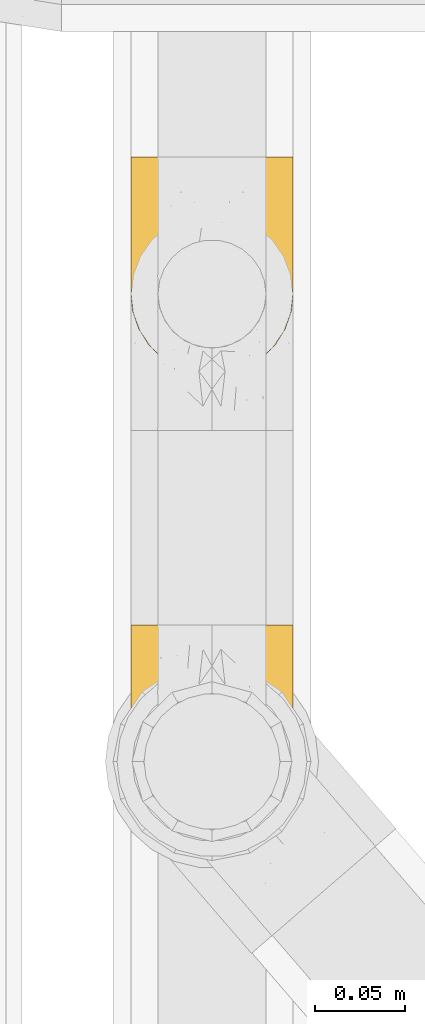
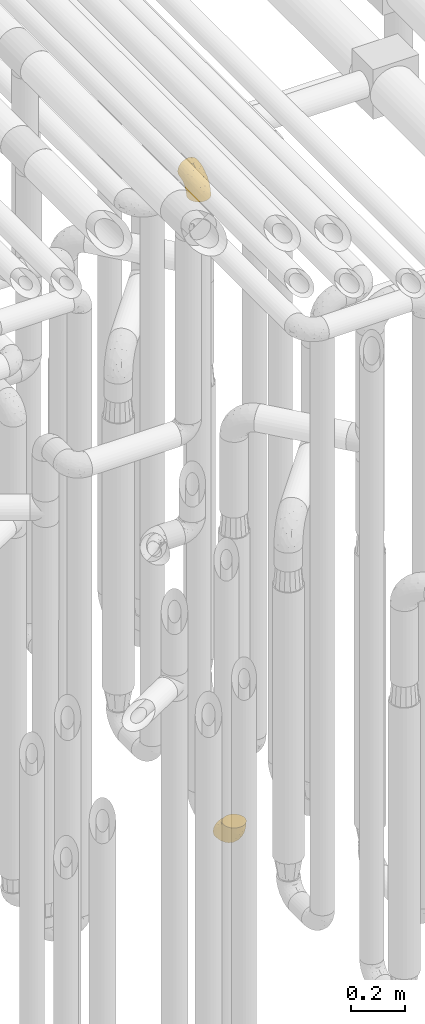
# One storey, part 213 of 827: 2 coverings.
"""IFC2X3 building model written with IfcOpenShell, lengths in millimetres."""

from ifc_helpers import new_model, entity, si_unit, converted_unit, derived_unit, direction, frame, origin, place, context, subcontext, project, spatial, faceted_brep, element, save


model = new_model("IFC2X3")

# Units and contexts
model_context = context("Model", 3, precision=0.01, world=origin(), true_north=direction((6.12303176911189e-17, 1.0)))
body_context = subcontext(model_context, "Body", "Model", "MODEL_VIEW")
ifc_project = project(units=[si_unit("LENGTHUNIT", "METRE", prefix="MILLI"), si_unit("AREAUNIT", "SQUARE_METRE"), si_unit("VOLUMEUNIT", "CUBIC_METRE"), converted_unit("PLANEANGLEUNIT", "DEGREE", entity("IfcRatioMeasure", 0.0174532925199433), si_unit("PLANEANGLEUNIT", "RADIAN"), dimensions=[0, 0, 0, 0, 0, 0, 0]), si_unit("MASSUNIT", "GRAM", prefix="KILO"), derived_unit("MASSDENSITYUNIT", [(si_unit("MASSUNIT", "GRAM", prefix="KILO"), 1), (si_unit("LENGTHUNIT", "METRE"), -3)]), derived_unit("MOMENTOFINERTIAUNIT", [(si_unit("LENGTHUNIT", "METRE"), 4)]), si_unit("TIMEUNIT", "SECOND"), si_unit("FREQUENCYUNIT", "HERTZ"), si_unit("THERMODYNAMICTEMPERATUREUNIT", "DEGREE_CELSIUS"), derived_unit("THERMALTRANSMITTANCEUNIT", [(si_unit("MASSUNIT", "GRAM", prefix="KILO"), 1), (si_unit("THERMODYNAMICTEMPERATUREUNIT", "KELVIN"), -1), (si_unit("TIMEUNIT", "SECOND"), -3)]), derived_unit("VOLUMETRICFLOWRATEUNIT", [(si_unit("LENGTHUNIT", "METRE"), 3), (si_unit("TIMEUNIT", "SECOND"), -1)]), derived_unit("MASSFLOWRATEUNIT", [(si_unit("MASSUNIT", "GRAM", prefix="KILO"), 1), (si_unit("TIMEUNIT", "SECOND"), -1)]), derived_unit("ROTATIONALFREQUENCYUNIT", [(si_unit("TIMEUNIT", "SECOND"), -1)]), si_unit("ELECTRICCURRENTUNIT", "AMPERE"), si_unit("ELECTRICVOLTAGEUNIT", "VOLT"), si_unit("POWERUNIT", "WATT"), si_unit("FORCEUNIT", "NEWTON", prefix="KILO"), si_unit("ILLUMINANCEUNIT", "LUX"), si_unit("LUMINOUSFLUXUNIT", "LUMEN"), si_unit("LUMINOUSINTENSITYUNIT", "CANDELA"), derived_unit("USERDEFINED", [(si_unit("MASSUNIT", "GRAM", prefix="KILO"), -1), (si_unit("LENGTHUNIT", "METRE"), -2), (si_unit("TIMEUNIT", "SECOND"), 3), (si_unit("LUMINOUSFLUXUNIT", "LUMEN"), 1)]), derived_unit("LINEARVELOCITYUNIT", [(si_unit("LENGTHUNIT", "METRE"), 1), (si_unit("TIMEUNIT", "SECOND"), -1)]), si_unit("PRESSUREUNIT", "PASCAL"), derived_unit("USERDEFINED", [(si_unit("LENGTHUNIT", "METRE"), -2), (si_unit("MASSUNIT", "GRAM", prefix="KILO"), 1), (si_unit("TIMEUNIT", "SECOND"), -2)]), derived_unit("LINEARFORCEUNIT", [(si_unit("MASSUNIT", "GRAM", prefix="KILO"), 1), (si_unit("LENGTHUNIT", "METRE"), 1), (si_unit("TIMEUNIT", "SECOND"), -2), (si_unit("LENGTHUNIT", "METRE"), -1)]), derived_unit("PLANARFORCEUNIT", [(si_unit("MASSUNIT", "GRAM", prefix="KILO"), 1), (si_unit("LENGTHUNIT", "METRE"), 1), (si_unit("TIMEUNIT", "SECOND"), -2), (si_unit("LENGTHUNIT", "METRE"), -2)])], contexts=[model_context])

# Site, building, storey
site_placement = place(None, origin())
site = spatial("IfcSite", under=ifc_project, at=site_placement, CompositionType="ELEMENT")
building_placement = place(site_placement, origin())
building = spatial("IfcBuilding", under=site, at=building_placement, CompositionType="ELEMENT")
storey_placement = place(building_placement, frame((0.0, 0.0, 28200.0)))
storey = spatial("IfcBuildingStorey", under=building, at=storey_placement, Name="08", CompositionType="ELEMENT", Elevation=28200.0)

# Coverings
covering_1_placement = place(storey_placement, frame((36582.9, 11683.46, 353.25)))
element("IfcCovering", 1, at=covering_1_placement, inside=storey, Name=":ADSK_", ObjectType=":ADSK_", PredefinedType="INSULATION", context=body_context, shape_type="Brep", body=[
    faceted_brep([(2.73, 36.69, 122.75), (6.07, 27.15, 122.75), (11.45, 18.59, 122.75), (18.6, 11.44, 122.75), (27.16, 6.06, 122.75), (36.7, 2.73, 122.75), (46.75, 1.6, 122.75), (56.8, 2.73, 122.75), (66.34, 6.07, 122.75), (74.9, 11.45, 122.75), (82.05, 18.6, 122.75), (87.43, 27.16, 122.75), (90.76, 36.7, 122.75), (91.9, 46.75, 122.75), (90.76, 56.8, 122.75), (87.42, 66.34, 122.75), (82.04, 74.9, 122.75), (74.89, 82.05, 122.75), (66.33, 87.43, 122.75), (56.79, 90.76, 122.75), (46.75, 91.9, 122.75), (36.69, 90.76, 122.75), (27.15, 87.42, 122.75), (18.59, 82.04, 122.75), (11.44, 74.89, 122.75), (6.06, 66.33, 122.75), (2.73, 56.79, 122.75), (1.6, 46.75, 122.75), (58.43, 122.75, 90.36), (69.32, 122.75, 85.85), (78.67, 122.75, 78.67), (85.85, 122.75, 69.32), (90.36, 122.75, 58.43), (91.9, 122.75, 46.75), (90.36, 122.75, 35.06), (85.85, 122.75, 24.17), (78.67, 122.75, 14.82), (69.32, 122.75, 7.64), (58.43, 122.75, 3.13), (46.75, 122.75, 1.6), (35.06, 122.75, 3.13), (24.17, 122.75, 7.64), (14.82, 122.75, 14.82), (7.64, 122.75, 24.17), (3.13, 122.75, 35.06), (1.6, 122.75, 46.75), (3.13, 122.75, 58.43), (7.64, 122.75, 69.32), (14.82, 122.75, 78.67), (24.17, 122.75, 85.85), (35.06, 122.75, 90.36), (46.75, 122.75, 91.9), (46.75, 24.73, 51.54), (38.29, 29.08, 47.17), (46.75, 38.13, 38.13), (46.75, 85.31, 7.52), (38.96, 93.59, 5.85), (46.75, 100.54, 5.11), (33.86, 63.54, 19.2), (31.42, 38.98, 38.98), (21.63, 50.71, 35.02), (30.84, 93.33, 8.21), (22.16, 75.2, 19.28), (20.56, 100.46, 12.19), (2.29, 41.6, 101.39), (7.18, 80.86, 34.43), (12.6, 94.87, 20.95), (14.0, 67.96, 30.74), (2.81, 52.16, 72.93), (6.65, 52.1, 56.64), (6.11, 36.74, 80.81), (16.62, 17.11, 93.43), (9.76, 23.24, 100.76), (12.46, 29.18, 74.27), (1.6, 52.53, 93.66), (1.6, 60.77, 81.33), (1.6, 69.01, 69.01), (2.46, 100.68, 40.87), (5.91, 103.79, 29.38), (36.97, 16.37, 67.05), (46.75, 7.52, 85.31), (33.09, 7.31, 93.68), (1.6, 93.66, 52.53), (1.6, 102.83, 50.71), (1.6, 112.01, 48.88), (25.62, 18.17, 72.77), (3.14, 71.97, 51.21), (23.92, 9.83, 101.18), (46.75, 5.11, 100.54), (13.58, 45.97, 48.74), (1.6, 48.88, 112.01), (1.6, 50.71, 102.83), (18.5, 22.83, 73.88), (46.75, 51.54, 24.73), (1.6, 81.33, 60.77), (4.96, 31.74, 103.08), (20.84, 32.48, 54.8), (46.75, 68.42, 16.13), (30.52, 25.33, 55.92), (46.75, 16.13, 68.42), (27.29, 92.29, 104.98), (36.89, 94.12, 108.58), (33.6, 100.97, 98.21), (2.54, 95.91, 61.56), (3.27, 107.9, 60.69), (16.85, 87.24, 100.0), (21.91, 95.46, 95.88), (13.5, 90.41, 90.81), (3.96, 74.17, 84.88), (3.52, 83.77, 73.29), (12.17, 76.72, 113.4), (18.93, 84.44, 109.8), (9.34, 76.42, 102.13), (3.12, 90.07, 67.29), (5.67, 99.69, 70.34), (2.51, 61.74, 95.15), (2.53, 58.16, 105.49), (8.35, 112.6, 71.5), (35.39, 110.45, 92.87), (46.75, 107.32, 96.03), (15.1, 108.48, 81.34), (5.27, 66.63, 107.44), (27.43, 115.23, 88.36), (24.89, 105.79, 90.43), (29.71, 89.6, 114.37), (5.07, 69.39, 98.41), (2.88, 66.99, 88.73), (9.69, 102.31, 76.89), (15.51, 99.54, 86.08), (2.27, 55.27, 112.64), (10.03, 82.03, 94.21), (46.75, 94.71, 112.22), (46.75, 96.03, 107.32), (8.83, 94.11, 79.95), (7.16, 84.21, 84.51), (46.75, 101.67, 101.67), (46.75, 112.22, 94.71), (78.39, 108.48, 81.34), (83.8, 102.31, 76.89), (77.97, 99.54, 86.08), (84.66, 94.11, 79.96), (58.1, 110.46, 92.87), (81.31, 76.74, 113.41), (91.9, 50.71, 102.83), (90.96, 58.17, 105.5), (91.22, 55.27, 112.64), (56.59, 94.12, 108.58), (66.18, 92.3, 104.98), (59.87, 100.98, 98.2), (88.42, 69.41, 98.4), (84.13, 76.44, 102.13), (88.22, 66.65, 107.44), (66.06, 115.24, 88.36), (91.9, 102.83, 50.71), (91.9, 112.01, 48.88), (83.44, 82.05, 94.22), (76.62, 87.25, 100.01), (85.14, 112.6, 71.5), (90.22, 107.9, 60.69), (91.9, 93.66, 52.53), (71.55, 95.48, 95.89), (63.77, 89.6, 114.37), (91.9, 60.77, 81.33), (91.9, 69.01, 69.01), (89.53, 74.17, 84.88), (91.9, 48.88, 112.01), (74.55, 84.45, 109.8), (90.95, 95.91, 61.56), (90.37, 90.07, 67.29), (91.9, 81.33, 60.77), (90.98, 61.75, 95.14), (89.97, 83.77, 73.29), (86.32, 84.21, 84.53), (91.9, 52.53, 93.66), (79.97, 90.42, 90.82), (90.61, 67.0, 88.73), (87.82, 99.69, 70.34), (68.6, 105.8, 90.43), (80.89, 94.87, 20.95), (86.31, 80.86, 34.43), (79.49, 67.95, 30.74), (71.33, 75.17, 19.29), (71.88, 50.65, 35.07), (90.35, 71.97, 51.21), (86.85, 52.08, 56.67), (72.67, 32.46, 54.85), (62.08, 38.98, 38.98), (87.58, 103.79, 29.38), (91.03, 100.68, 40.87), (59.62, 63.54, 19.2), (62.65, 93.32, 8.21), (54.53, 93.59, 5.85), (72.93, 100.44, 12.19), (90.68, 52.17, 72.93), (87.39, 36.75, 80.83), (91.2, 41.61, 101.39), (60.41, 7.31, 93.69), (76.88, 17.12, 93.43), (56.53, 16.37, 67.04), (83.74, 23.26, 100.76), (67.88, 18.17, 72.78), (62.99, 25.33, 55.93), (69.58, 9.84, 101.18), (81.04, 29.19, 74.27), (75.0, 22.84, 73.89), (88.53, 31.75, 103.09), (79.93, 45.96, 48.78), (55.21, 29.07, 47.19)], [[[0, 1, 2, 3, 4, 5, 6, 7, 8, 9, 10, 11, 12, 13, 14, 15, 16, 17, 18, 19, 20, 21, 22, 23, 24, 25, 26, 27]], [[28, 29, 30, 31, 32, 33, 34, 35, 36, 37, 38, 39, 40, 41, 42, 43, 44, 45, 46, 47, 48, 49, 50, 51]], [[52, 53, 54]], [[55, 56, 57]], [[58, 59, 60]], [[61, 62, 63]], [[27, 64, 0]], [[65, 66, 67]], [[41, 40, 61]], [[68, 69, 70]], [[66, 43, 42]], [[63, 42, 41]], [[71, 72, 73]], [[72, 2, 1]], [[68, 74, 75, 76]], [[45, 44, 77]], [[43, 78, 44]], [[79, 80, 81]], [[77, 82, 83, 84, 45]], [[79, 81, 85]], [[71, 2, 72]], [[65, 86, 77]], [[4, 81, 5]], [[66, 65, 78]], [[4, 3, 87]], [[81, 88, 5]], [[63, 66, 42]], [[68, 70, 64]], [[67, 60, 89]], [[71, 3, 2]], [[64, 27, 90, 91, 74]], [[92, 71, 73]], [[40, 57, 56]], [[59, 93, 54]], [[86, 76, 94, 82]], [[1, 0, 95]], [[58, 62, 61]], [[60, 96, 89]], [[85, 81, 87]], [[56, 97, 58]], [[65, 67, 69]], [[87, 81, 4]], [[67, 89, 69]], [[61, 63, 41]], [[95, 72, 1]], [[73, 72, 70]], [[69, 73, 70]], [[73, 89, 96]], [[3, 71, 87]], [[85, 87, 71]], [[58, 61, 56]], [[59, 58, 93]], [[76, 86, 68]], [[69, 89, 73]], [[68, 86, 69]], [[65, 69, 86]], [[68, 64, 74]], [[95, 64, 70]], [[98, 79, 85]], [[79, 52, 99, 80]], [[66, 62, 67]], [[62, 58, 60]], [[62, 60, 67]], [[59, 98, 96]], [[59, 96, 60]], [[96, 85, 92]], [[88, 81, 80]], [[88, 6, 5]], [[66, 63, 62]], [[64, 95, 0]], [[72, 95, 70]], [[77, 44, 78]], [[86, 82, 77]], [[40, 39, 57]], [[96, 98, 85]], [[40, 56, 61]], [[66, 78, 43]], [[77, 78, 65]], [[79, 98, 53]], [[96, 92, 73]], [[85, 71, 92]], [[97, 56, 55]], [[97, 93, 58]], [[53, 98, 59]], [[54, 53, 59]], [[79, 53, 52]], [[100, 101, 102]], [[46, 45, 84, 83]], [[103, 104, 82]], [[82, 104, 83]], [[105, 106, 107]], [[108, 109, 76]], [[110, 111, 112]], [[103, 113, 114]], [[115, 74, 116]], [[48, 47, 117]], [[118, 102, 119]], [[49, 48, 120]], [[74, 91, 116]], [[116, 121, 115]], [[49, 122, 50]], [[123, 106, 102]], [[124, 111, 22]], [[125, 126, 115]], [[23, 22, 111]], [[24, 110, 121]], [[120, 127, 128]], [[90, 26, 129]], [[27, 26, 90]], [[121, 125, 115]], [[24, 121, 25]], [[130, 105, 107]], [[129, 25, 116]], [[21, 20, 131]], [[120, 123, 122]], [[112, 105, 130]], [[50, 118, 51]], [[21, 124, 22]], [[101, 131, 132]], [[117, 120, 48]], [[24, 23, 110]], [[127, 114, 133]], [[75, 108, 76]], [[107, 134, 130]], [[133, 114, 113]], [[129, 116, 91]], [[25, 121, 116]], [[121, 112, 125]], [[75, 74, 115]], [[101, 135, 102]], [[131, 101, 21]], [[101, 100, 124]], [[128, 127, 133]], [[119, 136, 51, 118]], [[104, 47, 46]], [[83, 104, 46]], [[117, 104, 114]], [[101, 124, 21]], [[111, 124, 100]], [[102, 118, 123]], [[133, 134, 107]], [[111, 110, 23]], [[114, 104, 103]], [[94, 76, 109]], [[121, 110, 112]], [[122, 118, 50]], [[134, 109, 108]], [[133, 107, 128]], [[112, 108, 125]], [[126, 125, 108]], [[108, 75, 126]], [[75, 115, 126]], [[109, 134, 133]], [[130, 108, 112]], [[108, 130, 134]], [[105, 112, 111]], [[111, 100, 105]], [[106, 105, 100]], [[102, 106, 100]], [[128, 106, 123]], [[90, 129, 91]], [[25, 129, 26]], [[104, 117, 47]], [[117, 114, 127]], [[82, 94, 103]], [[113, 94, 109]], [[94, 113, 103]], [[133, 113, 109]], [[106, 128, 107]], [[123, 120, 128]], [[120, 122, 49]], [[118, 122, 123]], [[135, 101, 132]], [[135, 119, 102]], [[117, 127, 120]], [[30, 29, 137]], [[138, 139, 140]], [[51, 136, 119, 141]], [[142, 17, 16]], [[143, 144, 145]], [[146, 147, 148]], [[149, 150, 151]], [[152, 29, 28]], [[33, 32, 153, 154]], [[150, 155, 156]], [[157, 31, 30]], [[153, 158, 159]], [[29, 152, 137]], [[148, 141, 119]], [[156, 160, 147]], [[148, 135, 146]], [[137, 138, 157]], [[19, 161, 146]], [[162, 163, 164]], [[14, 13, 165]], [[153, 32, 158]], [[147, 161, 166]], [[18, 17, 166]], [[167, 168, 169]], [[166, 150, 156]], [[151, 150, 142]], [[151, 170, 149]], [[151, 16, 15]], [[171, 140, 172]], [[165, 143, 145]], [[173, 170, 144]], [[142, 166, 17]], [[19, 131, 20]], [[144, 170, 151]], [[18, 161, 19]], [[173, 144, 143]], [[140, 139, 174]], [[171, 164, 163]], [[164, 172, 155]], [[151, 15, 144]], [[145, 15, 14]], [[173, 162, 170]], [[149, 175, 164]], [[19, 146, 131]], [[132, 131, 146]], [[160, 148, 147]], [[159, 158, 167]], [[135, 132, 146]], [[158, 32, 31]], [[157, 158, 31]], [[167, 158, 176]], [[166, 161, 18]], [[146, 161, 147]], [[148, 177, 141]], [[171, 168, 140]], [[171, 163, 169]], [[151, 142, 16]], [[166, 142, 150]], [[152, 141, 177]], [[51, 141, 28]], [[138, 140, 176]], [[172, 140, 174]], [[175, 149, 170]], [[164, 150, 149]], [[170, 162, 175]], [[162, 164, 175]], [[155, 172, 174]], [[171, 172, 164]], [[155, 174, 156]], [[164, 155, 150]], [[160, 156, 174]], [[147, 166, 156]], [[139, 160, 174]], [[148, 160, 177]], [[15, 145, 144]], [[165, 145, 14]], [[137, 157, 30]], [[158, 157, 176]], [[168, 167, 176]], [[169, 159, 167]], [[140, 168, 176]], [[169, 168, 171]], [[137, 177, 139]], [[160, 139, 177]], [[141, 152, 28]], [[137, 152, 177]], [[148, 119, 135]], [[157, 138, 176]], [[139, 138, 137]], [[178, 179, 180]], [[181, 180, 182]], [[179, 183, 184]], [[185, 186, 182]], [[187, 188, 179]], [[188, 33, 154, 153, 159]], [[181, 189, 190]], [[35, 34, 187]], [[191, 38, 190]], [[192, 178, 181]], [[179, 184, 180]], [[192, 190, 37]], [[37, 190, 38]], [[36, 35, 178]], [[54, 93, 186]], [[35, 187, 178]], [[193, 194, 184]], [[195, 173, 143, 165, 13]], [[195, 193, 173]], [[193, 163, 162, 173]], [[13, 12, 195]], [[8, 7, 196]], [[9, 197, 10]], [[198, 80, 99, 52]], [[196, 7, 88]], [[197, 199, 10]], [[182, 189, 181]], [[200, 198, 201]], [[200, 196, 198]], [[9, 8, 202]], [[194, 199, 203]], [[192, 37, 36]], [[80, 196, 88]], [[183, 159, 169, 163]], [[188, 34, 33]], [[202, 200, 197]], [[185, 203, 204]], [[202, 8, 196]], [[10, 199, 11]], [[12, 11, 205]], [[38, 191, 57]], [[189, 97, 191]], [[203, 199, 197]], [[205, 199, 194]], [[204, 203, 197]], [[184, 203, 206]], [[200, 202, 196]], [[197, 9, 202]], [[207, 54, 186]], [[97, 55, 191]], [[194, 203, 184]], [[183, 163, 193]], [[184, 206, 180]], [[183, 193, 184]], [[205, 195, 12]], [[193, 195, 194]], [[80, 198, 196]], [[207, 186, 201]], [[182, 180, 206]], [[181, 178, 180]], [[185, 182, 206]], [[182, 186, 189]], [[203, 185, 206]], [[185, 200, 201]], [[7, 6, 88]], [[178, 192, 36]], [[190, 192, 181]], [[199, 205, 11]], [[195, 205, 194]], [[159, 183, 188]], [[179, 188, 183]], [[57, 191, 55]], [[57, 39, 38]], [[189, 191, 190]], [[188, 187, 34]], [[178, 187, 179]], [[186, 93, 189]], [[197, 200, 204]], [[185, 204, 200]], [[189, 93, 97]], [[207, 198, 52]], [[185, 201, 186]], [[198, 207, 201]], [[54, 207, 52]]]),
])
covering_2_placement = place(storey_placement, frame((36582.9, 11943.46, 3122.4)))
element("IfcCovering", 2, at=covering_2_placement, inside=storey, Name=":ADSK_", ObjectType=":ADSK_", PredefinedType="INSULATION", context=body_context, shape_type="Brep", body=[
    faceted_brep([(90.76, 36.69, 1.6), (87.42, 27.15, 1.6), (82.04, 18.59, 1.6), (74.89, 11.44, 1.6), (66.33, 6.06, 1.6), (56.79, 2.73, 1.6), (46.75, 1.6, 1.6), (36.69, 2.73, 1.6), (27.15, 6.07, 1.6), (18.59, 11.45, 1.6), (11.44, 18.6, 1.6), (6.06, 27.16, 1.6), (2.73, 36.7, 1.6), (1.6, 46.75, 1.6), (2.73, 56.8, 1.6), (6.07, 66.34, 1.6), (11.45, 74.9, 1.6), (18.6, 82.05, 1.6), (27.16, 87.43, 1.6), (36.7, 90.76, 1.6), (46.75, 91.9, 1.6), (56.8, 90.76, 1.6), (66.34, 87.42, 1.6), (74.9, 82.04, 1.6), (82.05, 74.89, 1.6), (87.43, 66.33, 1.6), (90.76, 56.79, 1.6), (91.9, 46.75, 1.6), (35.06, 122.75, 33.98), (24.17, 122.75, 38.49), (14.82, 122.75, 45.67), (7.64, 122.75, 55.02), (3.13, 122.75, 65.91), (1.6, 122.75, 77.6), (3.13, 122.75, 89.28), (7.64, 122.75, 100.17), (14.82, 122.75, 109.52), (24.17, 122.75, 116.7), (35.06, 122.75, 121.21), (46.75, 122.75, 122.75), (58.43, 122.75, 121.21), (69.32, 122.75, 116.7), (78.67, 122.75, 109.52), (85.85, 122.75, 100.17), (90.36, 122.75, 89.28), (91.9, 122.75, 77.6), (90.36, 122.75, 65.91), (85.85, 122.75, 55.02), (78.67, 122.75, 45.67), (69.32, 122.75, 38.49), (58.43, 122.75, 33.98), (46.75, 122.75, 32.45), (46.75, 24.73, 72.81), (55.2, 29.08, 77.17), (46.75, 38.13, 86.21), (46.75, 85.31, 116.82), (54.53, 93.59, 118.49), (46.75, 100.54, 119.23), (59.63, 63.54, 105.14), (62.07, 38.98, 85.37), (71.86, 50.71, 89.33), (62.65, 93.33, 116.14), (71.33, 75.2, 105.06), (72.93, 100.46, 112.15), (91.2, 41.6, 22.95), (86.31, 80.86, 89.91), (80.89, 94.87, 103.39), (79.49, 67.96, 93.6), (90.68, 52.16, 51.41), (86.84, 52.1, 67.71), (87.38, 36.74, 43.53), (76.87, 17.11, 30.91), (83.73, 23.24, 23.58), (81.03, 29.18, 50.07), (91.9, 52.53, 30.68), (91.9, 60.77, 43.01), (91.9, 69.01, 55.34), (91.03, 100.68, 83.48), (87.58, 103.79, 94.96), (56.52, 16.37, 57.29), (46.75, 7.52, 39.03), (60.4, 7.31, 30.66), (91.9, 93.66, 71.81), (91.9, 102.83, 73.63), (91.9, 112.01, 75.46), (67.87, 18.17, 51.57), (90.35, 71.97, 73.13), (69.57, 9.83, 23.16), (46.75, 5.11, 23.8), (79.91, 45.97, 75.6), (91.9, 48.88, 12.33), (91.9, 50.71, 21.51), (74.99, 22.83, 50.46), (46.75, 51.54, 99.61), (91.9, 81.33, 63.57), (88.53, 31.74, 21.26), (72.65, 32.48, 69.54), (46.75, 68.42, 108.21), (62.97, 25.33, 68.42), (46.75, 16.13, 55.92), (66.2, 92.29, 19.36), (56.6, 94.12, 15.76), (59.89, 100.97, 26.13), (90.95, 95.91, 62.78), (90.22, 107.9, 63.65), (76.64, 87.24, 24.34), (71.58, 95.46, 28.46), (79.99, 90.41, 33.53), (89.54, 74.17, 39.46), (89.97, 83.77, 51.05), (81.32, 76.72, 10.94), (74.56, 84.44, 14.55), (84.15, 76.42, 22.21), (90.37, 90.07, 57.05), (87.82, 99.69, 54.0), (90.98, 61.74, 29.19), (90.96, 58.16, 18.85), (85.14, 112.6, 52.84), (58.11, 110.45, 31.47), (46.75, 107.32, 28.31), (78.39, 108.48, 43.0), (88.22, 66.63, 16.9), (66.06, 115.23, 35.98), (68.6, 105.79, 33.91), (63.78, 89.6, 9.97), (88.42, 69.39, 25.93), (90.61, 66.99, 35.61), (83.8, 102.31, 47.45), (77.98, 99.54, 38.26), (91.22, 55.27, 11.7), (83.46, 82.03, 30.13), (46.75, 94.71, 12.12), (46.75, 96.03, 17.02), (84.66, 94.11, 44.39), (86.33, 84.21, 39.83), (46.75, 101.67, 22.67), (46.75, 112.22, 29.63), (15.1, 108.48, 43.0), (9.69, 102.31, 47.45), (15.52, 99.54, 38.26), (8.83, 94.11, 44.38), (35.39, 110.46, 31.47), (12.18, 76.74, 10.93), (1.6, 50.71, 21.51), (2.53, 58.17, 18.84), (2.27, 55.27, 11.7), (36.9, 94.12, 15.76), (27.31, 92.3, 19.36), (33.62, 100.98, 26.14), (5.07, 69.41, 25.94), (9.36, 76.44, 22.21), (5.27, 66.65, 16.9), (27.43, 115.24, 35.98), (1.6, 102.83, 73.63), (1.6, 112.01, 75.46), (10.05, 82.05, 30.12), (16.87, 87.25, 24.33), (8.35, 112.6, 52.84), (3.27, 107.9, 63.65), (1.6, 93.66, 71.81), (21.94, 95.48, 28.45), (29.72, 89.6, 9.97), (1.6, 60.77, 43.01), (1.6, 69.01, 55.34), (3.96, 74.17, 39.46), (1.6, 48.88, 12.33), (18.95, 84.45, 14.54), (2.54, 95.91, 62.78), (3.12, 90.07, 57.05), (1.6, 81.33, 63.57), (2.51, 61.75, 29.2), (3.52, 83.77, 51.05), (7.17, 84.21, 39.81), (1.6, 52.53, 30.68), (13.52, 90.42, 33.52), (2.88, 67.0, 35.61), (5.67, 99.69, 54.0), (24.89, 105.8, 33.91), (12.6, 94.87, 103.39), (7.18, 80.86, 89.91), (14.0, 67.95, 93.6), (22.16, 75.17, 105.05), (21.61, 50.65, 89.27), (3.14, 71.97, 73.13), (6.65, 52.08, 67.67), (20.82, 32.46, 69.49), (31.41, 38.98, 85.36), (5.91, 103.79, 94.96), (2.46, 100.68, 83.48), (33.87, 63.54, 105.14), (30.84, 93.32, 116.13), (38.96, 93.59, 118.49), (20.56, 100.44, 112.15), (2.81, 52.17, 51.41), (6.1, 36.75, 43.51), (2.29, 41.61, 22.95), (33.08, 7.31, 30.66), (16.61, 17.12, 30.91), (36.96, 16.37, 57.3), (9.75, 23.26, 23.58), (25.61, 18.17, 51.56), (30.5, 25.33, 68.41), (23.91, 9.84, 23.16), (12.45, 29.19, 50.07), (18.49, 22.84, 50.45), (4.96, 31.75, 21.25), (13.56, 45.96, 75.56), (38.28, 29.07, 77.16)], [[[0, 1, 2, 3, 4, 5, 6, 7, 8, 9, 10, 11, 12, 13, 14, 15, 16, 17, 18, 19, 20, 21, 22, 23, 24, 25, 26, 27]], [[28, 29, 30, 31, 32, 33, 34, 35, 36, 37, 38, 39, 40, 41, 42, 43, 44, 45, 46, 47, 48, 49, 50, 51]], [[52, 53, 54]], [[55, 56, 57]], [[58, 59, 60]], [[61, 62, 63]], [[27, 64, 0]], [[65, 66, 67]], [[41, 40, 61]], [[68, 69, 70]], [[66, 43, 42]], [[63, 42, 41]], [[71, 72, 73]], [[72, 2, 1]], [[68, 74, 75, 76]], [[45, 44, 77]], [[43, 78, 44]], [[79, 80, 81]], [[77, 82, 83, 84, 45]], [[79, 81, 85]], [[71, 2, 72]], [[65, 86, 77]], [[4, 81, 5]], [[66, 65, 78]], [[4, 3, 87]], [[81, 88, 5]], [[63, 66, 42]], [[68, 70, 64]], [[67, 60, 89]], [[71, 3, 2]], [[64, 27, 90, 91, 74]], [[92, 71, 73]], [[40, 57, 56]], [[59, 93, 54]], [[86, 76, 94, 82]], [[1, 0, 95]], [[58, 62, 61]], [[60, 96, 89]], [[85, 81, 87]], [[56, 97, 58]], [[65, 67, 69]], [[87, 81, 4]], [[67, 89, 69]], [[61, 63, 41]], [[95, 72, 1]], [[73, 72, 70]], [[69, 73, 70]], [[73, 89, 96]], [[3, 71, 87]], [[85, 87, 71]], [[58, 61, 56]], [[59, 58, 93]], [[76, 86, 68]], [[69, 89, 73]], [[68, 86, 69]], [[65, 69, 86]], [[68, 64, 74]], [[95, 64, 70]], [[98, 79, 85]], [[79, 52, 99, 80]], [[66, 62, 67]], [[62, 58, 60]], [[62, 60, 67]], [[59, 98, 96]], [[59, 96, 60]], [[96, 85, 92]], [[88, 81, 80]], [[88, 6, 5]], [[66, 63, 62]], [[64, 95, 0]], [[72, 95, 70]], [[77, 44, 78]], [[86, 82, 77]], [[40, 39, 57]], [[96, 98, 85]], [[40, 56, 61]], [[66, 78, 43]], [[77, 78, 65]], [[79, 98, 53]], [[96, 92, 73]], [[85, 71, 92]], [[97, 56, 55]], [[97, 93, 58]], [[53, 98, 59]], [[54, 53, 59]], [[79, 53, 52]], [[100, 101, 102]], [[46, 45, 84, 83]], [[103, 104, 82]], [[82, 104, 83]], [[105, 106, 107]], [[108, 109, 76]], [[110, 111, 112]], [[103, 113, 114]], [[115, 74, 116]], [[48, 47, 117]], [[118, 102, 119]], [[49, 48, 120]], [[74, 91, 116]], [[116, 121, 115]], [[49, 122, 50]], [[123, 106, 102]], [[124, 111, 22]], [[125, 126, 115]], [[23, 22, 111]], [[24, 110, 121]], [[120, 127, 128]], [[90, 26, 129]], [[27, 26, 90]], [[121, 125, 115]], [[24, 121, 25]], [[130, 105, 107]], [[129, 25, 116]], [[21, 20, 131]], [[120, 123, 122]], [[112, 105, 130]], [[50, 118, 51]], [[21, 124, 22]], [[101, 131, 132]], [[117, 120, 48]], [[24, 23, 110]], [[127, 114, 133]], [[75, 108, 76]], [[107, 134, 130]], [[133, 114, 113]], [[129, 116, 91]], [[25, 121, 116]], [[121, 112, 125]], [[75, 74, 115]], [[101, 135, 102]], [[131, 101, 21]], [[101, 100, 124]], [[128, 127, 133]], [[119, 136, 51, 118]], [[104, 47, 46]], [[83, 104, 46]], [[117, 104, 114]], [[101, 124, 21]], [[111, 124, 100]], [[102, 118, 123]], [[133, 134, 107]], [[111, 110, 23]], [[114, 104, 103]], [[94, 76, 109]], [[121, 110, 112]], [[122, 118, 50]], [[134, 109, 108]], [[133, 107, 128]], [[112, 108, 125]], [[126, 125, 108]], [[108, 75, 126]], [[75, 115, 126]], [[109, 134, 133]], [[130, 108, 112]], [[108, 130, 134]], [[105, 112, 111]], [[111, 100, 105]], [[106, 105, 100]], [[102, 106, 100]], [[128, 106, 123]], [[90, 129, 91]], [[25, 129, 26]], [[104, 117, 47]], [[117, 114, 127]], [[82, 94, 103]], [[113, 94, 109]], [[94, 113, 103]], [[133, 113, 109]], [[106, 128, 107]], [[123, 120, 128]], [[120, 122, 49]], [[118, 122, 123]], [[135, 101, 132]], [[135, 119, 102]], [[117, 127, 120]], [[30, 29, 137]], [[138, 139, 140]], [[51, 136, 119, 141]], [[142, 17, 16]], [[143, 144, 145]], [[146, 147, 148]], [[149, 150, 151]], [[152, 29, 28]], [[33, 32, 153, 154]], [[150, 155, 156]], [[157, 31, 30]], [[153, 158, 159]], [[29, 152, 137]], [[148, 141, 119]], [[156, 160, 147]], [[148, 135, 146]], [[137, 138, 157]], [[19, 161, 146]], [[162, 163, 164]], [[14, 13, 165]], [[153, 32, 158]], [[147, 161, 166]], [[18, 17, 166]], [[167, 168, 169]], [[166, 150, 156]], [[151, 150, 142]], [[151, 170, 149]], [[151, 16, 15]], [[171, 140, 172]], [[165, 143, 145]], [[173, 170, 144]], [[142, 166, 17]], [[19, 131, 20]], [[144, 170, 151]], [[18, 161, 19]], [[173, 144, 143]], [[140, 139, 174]], [[171, 164, 163]], [[164, 172, 155]], [[151, 15, 144]], [[145, 15, 14]], [[173, 162, 170]], [[149, 175, 164]], [[19, 146, 131]], [[132, 131, 146]], [[160, 148, 147]], [[159, 158, 167]], [[135, 132, 146]], [[158, 32, 31]], [[157, 158, 31]], [[167, 158, 176]], [[166, 161, 18]], [[146, 161, 147]], [[148, 177, 141]], [[171, 168, 140]], [[171, 163, 169]], [[151, 142, 16]], [[166, 142, 150]], [[152, 141, 177]], [[51, 141, 28]], [[138, 140, 176]], [[172, 140, 174]], [[175, 149, 170]], [[164, 150, 149]], [[170, 162, 175]], [[162, 164, 175]], [[155, 172, 174]], [[171, 172, 164]], [[155, 174, 156]], [[164, 155, 150]], [[160, 156, 174]], [[147, 166, 156]], [[139, 160, 174]], [[148, 160, 177]], [[15, 145, 144]], [[165, 145, 14]], [[137, 157, 30]], [[158, 157, 176]], [[168, 167, 176]], [[169, 159, 167]], [[140, 168, 176]], [[169, 168, 171]], [[137, 177, 139]], [[160, 139, 177]], [[141, 152, 28]], [[137, 152, 177]], [[148, 119, 135]], [[157, 138, 176]], [[139, 138, 137]], [[178, 179, 180]], [[181, 180, 182]], [[179, 183, 184]], [[185, 186, 182]], [[187, 188, 179]], [[188, 33, 154, 153, 159]], [[181, 189, 190]], [[35, 34, 187]], [[191, 38, 190]], [[192, 178, 181]], [[179, 184, 180]], [[192, 190, 37]], [[37, 190, 38]], [[36, 35, 178]], [[54, 93, 186]], [[35, 187, 178]], [[193, 194, 184]], [[195, 173, 143, 165, 13]], [[195, 193, 173]], [[193, 163, 162, 173]], [[13, 12, 195]], [[8, 7, 196]], [[9, 197, 10]], [[198, 80, 99, 52]], [[196, 7, 88]], [[197, 199, 10]], [[182, 189, 181]], [[200, 198, 201]], [[200, 196, 198]], [[9, 8, 202]], [[194, 199, 203]], [[192, 37, 36]], [[80, 196, 88]], [[183, 159, 169, 163]], [[188, 34, 33]], [[202, 200, 197]], [[185, 203, 204]], [[202, 8, 196]], [[10, 199, 11]], [[12, 11, 205]], [[38, 191, 57]], [[189, 97, 191]], [[203, 199, 197]], [[205, 199, 194]], [[204, 203, 197]], [[184, 203, 206]], [[200, 202, 196]], [[197, 9, 202]], [[207, 54, 186]], [[97, 55, 191]], [[194, 203, 184]], [[183, 163, 193]], [[184, 206, 180]], [[183, 193, 184]], [[205, 195, 12]], [[193, 195, 194]], [[80, 198, 196]], [[207, 186, 201]], [[182, 180, 206]], [[181, 178, 180]], [[185, 182, 206]], [[182, 186, 189]], [[203, 185, 206]], [[185, 200, 201]], [[7, 6, 88]], [[178, 192, 36]], [[190, 192, 181]], [[199, 205, 11]], [[195, 205, 194]], [[159, 183, 188]], [[179, 188, 183]], [[57, 191, 55]], [[57, 39, 38]], [[189, 191, 190]], [[188, 187, 34]], [[178, 187, 179]], [[186, 93, 189]], [[197, 200, 204]], [[185, 204, 200]], [[189, 93, 97]], [[207, 198, 52]], [[185, 201, 186]], [[198, 207, 201]], [[54, 207, 52]]]),
])

save(model, "model.ifc")
